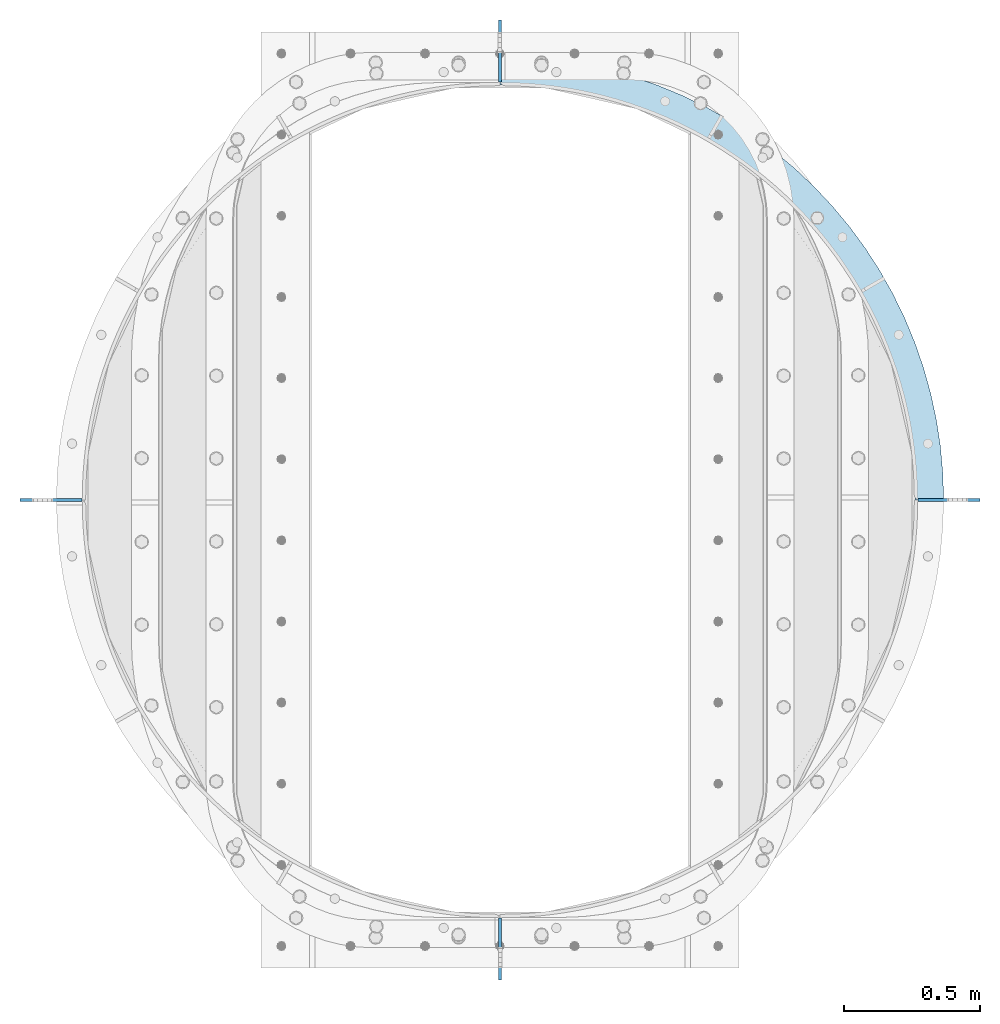
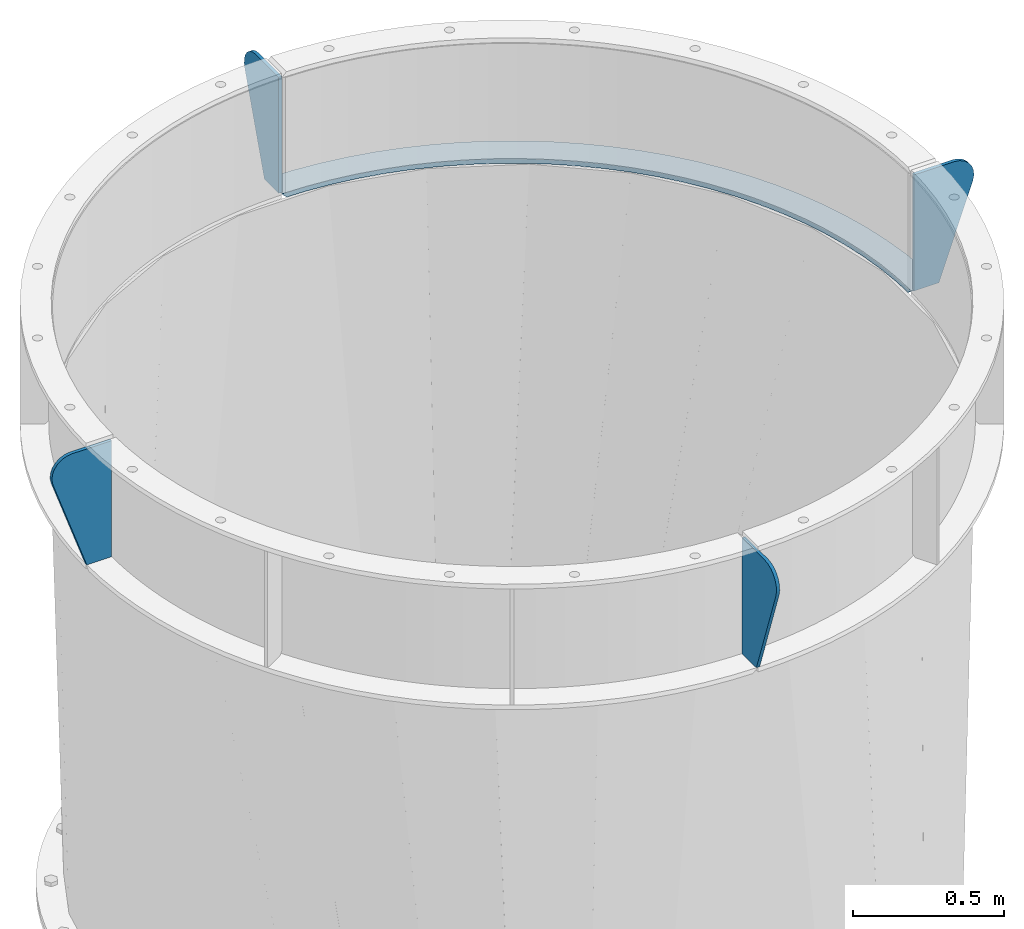
# One storey, part 15 of 15: 5 plates, 1 element without a shape of its own.
"""IFC2X3 building model written with IfcOpenShell, lengths in millimetres."""

import ifcopenshell
import ifcopenshell.guid

model = None  # the IFC model being written
_history = None  # IfcOwnerHistory: only IFC2X3 demands one
_inside = {}  # id of a spatial element -> (the spatial element, [elements in it])
_under = {}  # id of a project, library or spatial element -> (it, [spatial elements below it])
_declared = {}  # id of a project -> (the project, [libraries it declares])
_typed = {}  # id of a type object -> (the type object, [elements of that type])
_made_of = {}  # id of a material, layer set ... -> (it, [elements and type objects made of it])


def new_model(schema):
    """Start an empty IFC model of exactly this schema.

    Asked for "IFC4X3", IfcOpenShell would pick the latest addendum, in which some entities
    have other attributes; the version numbers below select the first issue.
    IFC2X3 requires an IfcOwnerHistory on every rooted entity: one is made here for all.
    """
    global model, _history
    if schema == "IFC4X3":
        model = ifcopenshell.file(schema_version=(4, 3, 0, 0))
    else:
        model = ifcopenshell.file(schema=schema)
    _inside.clear()
    _under.clear()
    _declared.clear()
    _typed.clear()
    _made_of.clear()
    _history = None
    if model.schema == "IFC2X3":
        org = make("IfcOrganization", Name="unknown")
        user = make(
            "IfcPersonAndOrganization",
            ThePerson=make("IfcPerson", FamilyName="unknown"),
            TheOrganization=org,
        )
        app = make(
            "IfcApplication",
            ApplicationDeveloper=org,
            Version="unknown",
            ApplicationFullName="unknown",
            ApplicationIdentifier="unknown",
        )
        _history = make(
            "IfcOwnerHistory",
            OwningUser=user,
            OwningApplication=app,
            ChangeAction="ADDED",
            CreationDate=0,
        )
    return model


def make(cls, **values):
    """One entity of the class cls with the attributes given. An attribute that is None is left unset."""
    return model.create_entity(
        cls, **{name: value for name, value in values.items() if value is not None}
    )


def rooted(cls, **values):
    """An entity with a GlobalId (a new one), such as an element, a storey or a relation."""
    return make(cls, GlobalId=ifcopenshell.guid.new(), OwnerHistory=_history, **values)


def si_unit(unit_type, name, prefix=None):
    """IfcSIUnit, for example si_unit("LENGTHUNIT", "METRE", prefix="MILLI")."""
    return make("IfcSIUnit", UnitType=unit_type, Prefix=prefix, Name=name)


def assignment(units):
    """IfcUnitAssignment: the units of a project."""
    return None if units is None else make("IfcUnitAssignment", Units=units)


def point(xyz):
    """IfcCartesianPoint."""
    return None if xyz is None else make("IfcCartesianPoint", Coordinates=xyz)


def direction(xyz):
    """IfcDirection."""
    return None if xyz is None else make("IfcDirection", DirectionRatios=xyz)


def frame(location, z_axis=None, x_axis=None):
    """IfcAxis2Placement3D, a coordinate frame: its origin and axes. An axis left out is left unset."""
    return make(
        "IfcAxis2Placement3D",
        Location=point(location),
        Axis=direction(z_axis),
        RefDirection=direction(x_axis),
    )


def origin_with_axes():
    """The frame at (0, 0, 0) with the z axis (0, 0, 1) and the x axis (1, 0, 0) written out."""
    return frame((0.0, 0.0, 0.0), z_axis=(0.0, 0.0, 1.0), x_axis=(1.0, 0.0, 0.0))


def place(relative_to, where):
    """IfcLocalPlacement: puts the frame where relative to a parent placement (None: the world)."""
    return make(
        "IfcLocalPlacement", PlacementRelTo=relative_to, RelativePlacement=where
    )


def context(
    kind, dimensions, precision=None, world=None, true_north=None, identifier=None
):
    """IfcGeometricRepresentationContext, for example the 3D "Model" context."""
    return make(
        "IfcGeometricRepresentationContext",
        ContextIdentifier=identifier,
        ContextType=kind,
        CoordinateSpaceDimension=dimensions,
        Precision=precision,
        WorldCoordinateSystem=world,
        TrueNorth=true_north,
    )


def subcontext(parent, identifier, kind, view, scale=None):
    """IfcGeometricRepresentationSubContext, for example "Body" below "Model"."""
    return make(
        "IfcGeometricRepresentationSubContext",
        ContextIdentifier=identifier,
        ContextType=kind,
        ParentContext=parent,
        TargetScale=scale,
        TargetView=view,
    )


def project(units=None, contexts=None):
    """IfcProject with its units and contexts."""
    return rooted(
        "IfcProject",
        Name="project",
        RepresentationContexts=contexts,
        UnitsInContext=assignment(units),
    )


def spatial(cls, under=None, at=None, **own):
    """A site, building, storey or space (cls), placed at a placement, below another one or the project."""
    s = rooted(cls, ObjectPlacement=at, **own)
    if under is not None:
        _under.setdefault(under.id(), (under, []))[1].append(s)
    return s


def faces_of(points, faces, orient=None, outer=None):
    """IfcFace entities. A face is a list of loops; a loop is a list of indices into points, from 0.

    orient and outer hold one flag for each loop. By default every Orientation is true, the
    first loop of a face is its IfcFaceOuterBound and the others are IfcFaceBound.
    """
    made = []
    for i, loops in enumerate(faces):
        bounds = []
        for j, loop in enumerate(loops):
            is_outer = j == 0 if outer is None else outer[i][j]
            bounds.append(
                make(
                    "IfcFaceOuterBound" if is_outer else "IfcFaceBound",
                    Bound=make("IfcPolyLoop", Polygon=[points[k] for k in loop]),
                    Orientation=True if orient is None else orient[i][j],
                )
            )
        made.append(make("IfcFace", Bounds=bounds))
    return made


def faceted_brep(points, faces, orient=None, outer=None, voids=None):
    """IfcFacetedBrep: a solid bounded by flat faces; with voids (closed shells), ...WithVoids."""
    shared = [point(p) for p in points]
    hull = make("IfcClosedShell", CfsFaces=faces_of(shared, faces, orient, outer))
    if voids is None:
        return make("IfcFacetedBrep", Outer=hull)
    return make(
        "IfcFacetedBrepWithVoids",
        Outer=hull,
        Voids=[
            make(cls, CfsFaces=faces_of(shared, fs, o, b)) for cls, fs, o, b in voids
        ],
    )


def shape(context_of_items, identifier, shape_type, items):
    """IfcShapeRepresentation: the items that make up one representation, for example the "Body"."""
    return make(
        "IfcShapeRepresentation",
        ContextOfItems=context_of_items,
        RepresentationIdentifier=identifier,
        RepresentationType=shape_type,
        Items=items,
    )


def material(Name=None, Category=None):
    """IfcMaterial."""
    return make("IfcMaterial", Name=Name, Category=Category)


def made_of(thing, what):
    """Note that an element or type object is made of a material, layer set ...; save() writes the relation."""
    if what is not None:
        _made_of.setdefault(what.id(), (what, []))[1].append(thing)
    return thing


def type_object(cls, material=None, **own):
    """A type object (cls), such as IfcWallType, which elements share."""
    return made_of(rooted(cls, **own), material)


def element(
    cls,
    number,
    at=None,
    inside=None,
    cuts=None,
    type_object=None,
    material=None,
    context=None,
    identifier="Body",
    shape_type=None,
    held_by="IfcProductDefinitionShape",
    body=None,
    shapes=None,
    **own,
):
    """One element of the class cls, such as IfcWall. Its Tag is "e" and its number.

    at: its placement. inside: the storey or other place that contains it. cuts: it is an
    opening in that element (IfcRelVoidsElement). A single representation is given by context,
    identifier, shape_type and body (its items); several are given by shapes. held_by: the class
    of the entity that holds the representations. save() writes the other relations.
    """
    e = rooted(cls, Tag="e%d" % number, ObjectPlacement=at, **own)
    if body is not None:
        shapes = [shape(context, identifier, shape_type, body)]
    if shapes is not None:
        e.Representation = make(held_by, Representations=shapes)
    if inside is not None:
        _inside.setdefault(inside.id(), (inside, []))[1].append(e)
    if cuts is not None:
        rooted(
            "IfcRelVoidsElement", RelatingBuildingElement=cuts, RelatedOpeningElement=e
        )
    if type_object is not None:
        _typed.setdefault(type_object.id(), (type_object, []))[1].append(e)
    return made_of(e, material)


def aggregate(whole, parts):
    """IfcRelAggregates: a whole, such as a stair, and the parts it consists of."""
    return rooted("IfcRelAggregates", RelatingObject=whole, RelatedObjects=parts)


def save(model, path):
    """Write the relations noted so far, then the file.

    IfcRelAggregates (storeys below a building ...), IfcRelContainedInSpatialStructure (elements
    in a storey), IfcRelDefinesByType, IfcRelAssociatesMaterial and IfcRelDeclares: one each for
    every whole, place, type object, material and project.
    """
    for whole, parts in _under.values():
        aggregate(whole, parts)
    for where, things in _inside.values():
        rooted(
            "IfcRelContainedInSpatialStructure",
            RelatedElements=things,
            RelatingStructure=where,
        )
    for kind, things in _typed.values():
        rooted("IfcRelDefinesByType", RelatedObjects=things, RelatingType=kind)
    for what, things in _made_of.values():
        rooted("IfcRelAssociatesMaterial", RelatedObjects=things, RelatingMaterial=what)
    for by, libraries in _declared.values():
        rooted("IfcRelDeclares", RelatingContext=by, RelatedDefinitions=libraries)
    model.write(path)


model = new_model("IFC2X3")

# Units and contexts
model_context = context("Model", 3, precision=1e-05, world=origin_with_axes())
body_context = subcontext(model_context, "Body", "Model", "MODEL_VIEW")
ifc_project = project(units=[si_unit("LENGTHUNIT", "METRE", prefix="MILLI"), si_unit("AREAUNIT", "SQUARE_METRE"), si_unit("VOLUMEUNIT", "CUBIC_METRE"), si_unit("MASSUNIT", "GRAM", prefix="KILO"), si_unit("TIMEUNIT", "SECOND"), si_unit("PLANEANGLEUNIT", "RADIAN"), si_unit("SOLIDANGLEUNIT", "STERADIAN"), si_unit("THERMODYNAMICTEMPERATUREUNIT", "DEGREE_CELSIUS"), si_unit("LUMINOUSINTENSITYUNIT", "LUMEN")], contexts=[model_context])

# Site, building, storey
site_placement = place(None, origin_with_axes())
site = spatial("IfcSite", under=ifc_project, at=site_placement, CompositionType="ELEMENT")
building_placement = place(site_placement, origin_with_axes())
building = spatial("IfcBuilding", under=site, at=building_placement, Name="Undefined", CompositionType="ELEMENT")
storey_placement = place(building_placement, origin_with_axes())
storey = spatial("IfcBuildingStorey", under=building, at=storey_placement, Name="Undefined", CompositionType="ELEMENT", Elevation=0.0)

# Assembly, plates
assembly_placement = place(storey_placement, origin_with_axes())
assembly = element("IfcElementAssembly", 1, at=assembly_placement, inside=storey, Name="TRANSITION", AssemblyPlace="NOTDEFINED", PredefinedType="RIGID_FRAME")
ifc_material = material(Name="STEEL/A36")
plate_type_1 = type_object("IfcPlateType", PredefinedType="NOTDEFINED")
plate_1_placement = place(assembly_placement, frame((-657.225000000269, 1720.85000000022, 6283.33), z_axis=(-1.0, 0.0, 0.0), x_axis=(0.0, 0.0, 1.0)))
plate_1 = element("IfcPlate", 2, at=plate_1_placement, type_object=plate_type_1, material=ifc_material, Name="PLATE", context=body_context, shape_type="Brep", body=[
    faceted_brep([(0.0, -6.34999999999991, 0.0), (1.81898940354586e-12, -6.34999999999991, 95.25), (1.81898940354586e-12, 6.34999999999991, 95.25), (0.0, 6.34999999999991, 0.0), (368.44076401667, -6.34999999999991, 224.702166797296), (368.44076401667, 6.34999999999991, 224.702166797296), (388.734484587208, -6.34999999999991, 228.848545423262), (388.734484587208, 6.34999999999991, 228.848545423262), (409.395098086102, -6.34999999999991, 227.376607872126), (409.395098086102, 6.34999999999991, 227.376607872126), (428.896028313952, -6.34999999999991, 220.395113006865), (428.896028313952, 6.34999999999991, 220.395113006865), (445.796386017711, -6.34999999999991, 208.419911138413), (445.796386017711, 6.34999999999991, 208.419911138413), (458.847433649809, -6.34999999999991, 192.335828758313), (458.847433649809, 6.34999999999991, 192.335828758313), (467.084852377538, -6.34999999999991, 173.331290273803), (467.084852377538, 6.34999999999991, 173.331290273803), (469.899993896484, -6.34999999999991, 152.81050742974), (469.899993896484, 6.34999999999991, 152.81050742974), (469.899993896484, -6.34999999999991, 1.81898940354586e-12), (469.899993896484, 6.34999999999991, 1.81898940354586e-12)], [[[0, 1, 2, 3]], [[1, 4, 5, 2]], [[4, 6, 7, 5]], [[6, 8, 9, 7]], [[8, 10, 11, 9]], [[10, 12, 13, 11]], [[12, 14, 15, 13]], [[14, 16, 17, 15]], [[16, 18, 19, 17]], [[18, 20, 21, 19]], [[20, 0, 3, 21]], [[5, 7, 9, 11, 13, 15, 17, 19, 21, 3, 2]], [[20, 18, 16, 14, 12, 10, 8, 6, 4, 1, 0]]]),
])
plate_2_placement = place(assembly_placement, frame((879.47499999978, 184.149999999731, 6283.33), z_axis=(0.0, -1.0, 0.0), x_axis=(0.0, 0.0, 1.0)))
plate_2 = element("IfcPlate", 3, at=plate_2_placement, type_object=plate_type_1, material=ifc_material, Name="PLATE", context=body_context, shape_type="Brep", body=[
    faceted_brep([(0.0, -6.34999999999991, 0.0), (1.81898940354586e-12, -6.34999999999991, 95.25), (1.81898940354586e-12, 6.34999999999991, 95.25), (0.0, 6.34999999999991, 0.0), (368.44076401667, -6.34999999999991, 224.702166797296), (368.44076401667, 6.34999999999991, 224.702166797296), (388.734484587208, -6.34999999999991, 228.848545423262), (388.734484587208, 6.34999999999991, 228.848545423262), (409.395098086102, -6.34999999999991, 227.376607872126), (409.395098086102, 6.34999999999991, 227.376607872126), (428.896028313952, -6.34999999999991, 220.395113006865), (428.896028313952, 6.34999999999991, 220.395113006865), (445.796386017711, -6.34999999999991, 208.419911138413), (445.796386017711, 6.34999999999991, 208.419911138413), (458.847433649809, -6.34999999999991, 192.335828758313), (458.847433649809, 6.34999999999991, 192.335828758313), (467.084852377538, -6.34999999999991, 173.331290273803), (467.084852377538, 6.34999999999991, 173.331290273803), (469.899993896484, -6.34999999999991, 152.81050742974), (469.899993896484, 6.34999999999991, 152.81050742974), (469.899993896484, -6.34999999999991, 1.81898940354586e-12), (469.899993896484, 6.34999999999991, 1.81898940354586e-12)], [[[0, 1, 2, 3]], [[1, 4, 5, 2]], [[4, 6, 7, 5]], [[6, 8, 9, 7]], [[8, 10, 11, 9]], [[10, 12, 13, 11]], [[12, 14, 15, 13]], [[14, 16, 17, 15]], [[16, 18, 19, 17]], [[18, 20, 21, 19]], [[20, 0, 3, 21]], [[5, 7, 9, 11, 13, 15, 17, 19, 21, 3, 2]], [[20, 18, 16, 14, 12, 10, 8, 6, 4, 1, 0]]]),
])
plate_3_placement = place(assembly_placement, frame((2416.17500000027, 1720.84999999978, 6283.33), z_axis=(1.0, 0.0, 0.0), x_axis=(0.0, 0.0, 1.0)))
plate_3 = element("IfcPlate", 4, at=plate_3_placement, type_object=plate_type_1, material=ifc_material, Name="PLATE", context=body_context, shape_type="Brep", body=[
    faceted_brep([(0.0, -6.34999999999991, 0.0), (1.81898940354586e-12, -6.34999999999991, 95.25), (1.81898940354586e-12, 6.34999999999991, 95.25), (0.0, 6.34999999999991, 0.0), (368.44076401667, -6.34999999999991, 224.702166797296), (368.44076401667, 6.34999999999991, 224.702166797296), (388.734484587208, -6.34999999999991, 228.848545423262), (388.734484587208, 6.34999999999991, 228.848545423262), (409.395098086102, -6.34999999999991, 227.376607872126), (409.395098086102, 6.34999999999991, 227.376607872126), (428.896028313952, -6.34999999999991, 220.395113006865), (428.896028313952, 6.34999999999991, 220.395113006865), (445.796386017711, -6.34999999999991, 208.419911138413), (445.796386017711, 6.34999999999991, 208.419911138413), (458.847433649809, -6.34999999999991, 192.335828758313), (458.847433649809, 6.34999999999991, 192.335828758313), (467.084852377538, -6.34999999999991, 173.331290273803), (467.084852377538, 6.34999999999991, 173.331290273803), (469.899993896484, -6.34999999999991, 152.81050742974), (469.899993896484, 6.34999999999991, 152.81050742974), (469.899993896484, -6.34999999999991, 1.81898940354586e-12), (469.899993896484, 6.34999999999991, 1.81898940354586e-12)], [[[0, 1, 2, 3]], [[1, 4, 5, 2]], [[4, 6, 7, 5]], [[6, 8, 9, 7]], [[8, 10, 11, 9]], [[10, 12, 13, 11]], [[12, 14, 15, 13]], [[14, 16, 17, 15]], [[16, 18, 19, 17]], [[18, 20, 21, 19]], [[20, 0, 3, 21]], [[5, 7, 9, 11, 13, 15, 17, 19, 21, 3, 2]], [[20, 18, 16, 14, 12, 10, 8, 6, 4, 1, 0]]]),
])
plate_4_placement = place(assembly_placement, frame((879.47500000022, 3257.55000000027, 6283.325), z_axis=(0.0, 1.0, 0.0), x_axis=(0.0, 0.0, 1.0)))
plate_4 = element("IfcPlate", 5, at=plate_4_placement, type_object=plate_type_1, material=ifc_material, Name="PLATE", context=body_context, shape_type="Brep", body=[
    faceted_brep([(0.0, -6.34999999999991, 0.0), (1.81898940354586e-12, -6.34999999999991, 95.25), (1.81898940354586e-12, 6.34999999999991, 95.25), (0.0, 6.34999999999991, 0.0), (368.44076401667, -6.34999999999991, 224.702166797296), (368.44076401667, 6.34999999999991, 224.702166797296), (388.734484587208, -6.34999999999991, 228.848545423262), (388.734484587208, 6.34999999999991, 228.848545423262), (409.395098086102, -6.34999999999991, 227.376607872126), (409.395098086102, 6.34999999999991, 227.376607872126), (428.896028313952, -6.34999999999991, 220.395113006865), (428.896028313952, 6.34999999999991, 220.395113006865), (445.796386017711, -6.34999999999991, 208.419911138413), (445.796386017711, 6.34999999999991, 208.419911138413), (458.847433649809, -6.34999999999991, 192.335828758313), (458.847433649809, 6.34999999999991, 192.335828758313), (467.084852377538, -6.34999999999991, 173.331290273803), (467.084852377538, 6.34999999999991, 173.331290273803), (469.899993896484, -6.34999999999991, 152.81050742974), (469.899993896484, 6.34999999999991, 152.81050742974), (469.899993896484, -6.34999999999991, 1.81898940354586e-12), (469.899993896484, 6.34999999999991, 1.81898940354586e-12)], [[[0, 1, 2, 3]], [[1, 4, 5, 2]], [[4, 6, 7, 5]], [[6, 8, 9, 7]], [[8, 10, 11, 9]], [[10, 12, 13, 11]], [[12, 14, 15, 13]], [[14, 16, 17, 15]], [[16, 18, 19, 17]], [[18, 20, 21, 19]], [[20, 0, 3, 21]], [[5, 7, 9, 11, 13, 15, 17, 19, 21, 3, 2]], [[20, 18, 16, 14, 12, 10, 8, 6, 4, 1, 0]]]),
])
plate_type_2 = type_object("IfcPlateType", PredefinedType="NOTDEFINED")
plate_5_placement = place(assembly_placement, frame((879.475000000271, 3352.79999999978, 6273.805), z_axis=(1.0, 0.0, 0.0), x_axis=(0.0, -1.0, 0.0)))
plate_5 = element("IfcPlate", 6, at=plate_5_placement, type_object=plate_type_2, material=ifc_material, Name="PLATE", context=body_context, shape_type="Brep", body=[
    faceted_brep([(103.76313049706, 9.52499999999964, 19.05), (103.1875, -9.52499999999964, 0.0), (0.0, -9.52499999999964, 0.0), (0.57563035489018, 9.52499999999964, 19.05), (1612.89995117188, 9.52499999999964, 1631.37432081696), (1631.94995117188, -9.52499999999964, 1631.94995117188), (1631.94995117188, -9.52499999999964, 1528.76245117188), (1612.89995117188, 9.52499999999964, 1528.18682067481), (2.97740452312382, -9.52499999999964, 98.5346858164392), (2.97740452312382, 9.52499999999964, 98.5346858164392), (11.8987531805783, -9.52499999999964, 196.709829232645), (11.8987531805783, 9.52499999999964, 196.709829232645), (26.7314929387344, -9.52499999999964, 294.167199800127), (26.7314929387344, 9.52499999999964, 294.167199800127), (47.4215007392556, -9.52499999999964, 390.55118614576), (47.4215007392556, 9.52499999999964, 390.55118614576), (73.8932809881087, -9.52499999999964, 485.510093559006), (73.8932809881087, 9.52499999999964, 485.510093559006), (106.050241030797, -9.52499999999964, 578.697427287759), (106.050241030797, 9.52499999999964, 578.697427287759), (143.77504360848, -9.52499999999964, 669.77315686011), (143.77504360848, 9.52499999999964, 669.77315686011), (186.930035008899, -9.52499999999964, 758.404956818652), (186.930035008899, 9.52499999999964, 758.404956818652), (235.357747349844, -9.52499999999964, 844.269419340023), (235.357747349844, 9.52499999999964, 844.269419340023), (288.881473162371, -9.52499999999964, 927.053234314973), (288.881473162371, 9.52499999999964, 927.053234314973), (347.30591017719, -9.52499999999964, 1006.45433258296), (347.30591017719, 9.52499999999964, 1006.45433258296), (410.417873961457, -9.52499999999964, 1082.18298814976), (410.417873961457, 9.52499999999964, 1082.18298814976), (477.987075805645, -9.52499999999964, 1153.96287536617), (477.987075805645, 9.52499999999964, 1153.96287536617), (549.766963022063, -9.52499999999964, 1221.53207721036), (549.766963022063, 9.52499999999964, 1221.53207721036), (625.495618588867, -9.52499999999964, 1284.64404099462), (625.495618588867, 9.52499999999964, 1284.64404099462), (704.896716856861, -9.52499999999964, 1343.06847800943), (704.896716856861, 9.52499999999964, 1343.06847800943), (787.680531831816, -9.52499999999964, 1396.59220382195), (787.680531831816, 9.52499999999964, 1396.59220382195), (873.544994353191, -9.52499999999964, 1445.01991616288), (873.544994353191, 9.52499999999964, 1445.01991616288), (962.176794311736, -9.52499999999964, 1488.1749075633), (962.176794311736, 9.52499999999964, 1488.1749075633), (1053.25252388409, -9.52499999999964, 1525.89971014097), (1053.25252388409, 9.52499999999964, 1525.89971014097), (1146.43985761284, -9.52499999999964, 1558.05667018365), (1146.43985761284, 9.52499999999964, 1558.05667018365), (1241.39876502609, -9.52499999999964, 1584.52845043249), (1241.39876502609, 9.52499999999964, 1584.52845043249), (1337.78275137173, -9.52499999999964, 1605.21845823301), (1337.78275137173, 9.52499999999964, 1605.21845823301), (1435.24012193921, -9.52499999999964, 1620.05119799115), (1435.24012193921, 9.52499999999964, 1620.05119799115), (1533.41526535541, -9.52499999999964, 1628.9725466486), (1533.41526535541, 9.52499999999964, 1628.9725466486), (1539.64557176765, -9.52499999999964, 1525.97330598564), (1539.64557176765, 9.52499999999964, 1525.97330598564), (1447.67800108681, -9.52499999999964, 1517.61604978902), (1447.67800108681, 9.52499999999964, 1517.61604978902), (1356.3828188116, -9.52499999999964, 1503.7211773028), (1356.3828188116, 9.52499999999964, 1503.7211773028), (1266.09315115196, -9.52499999999964, 1484.33938940837), (1266.09315115196, 9.52499999999964, 1484.33938940837), (1177.13845530415, -9.52499999999964, 1459.54140814586), (1177.13845530415, 9.52499999999964, 1459.54140814586), (1089.84331729719, -9.52499999999964, 1429.41771865703), (1089.84331729719, 9.52499999999964, 1429.41771865703), (1004.5262676137, -9.52499999999964, 1394.07823901488), (1004.5262676137, 9.52499999999964, 1394.07823901488), (921.498618906718, -9.52499999999964, 1353.65191914449), (921.498618906718, 9.52499999999964, 1353.65191914449), (841.063330053642, -9.52499999999964, 1308.28627029875), (841.063330053642, 9.52499999999964, 1308.28627029875), (763.513900692163, -9.52499999999964, 1258.1468268058), (763.513900692163, 9.52499999999964, 1258.1468268058), (689.133300271954, -9.52499999999964, 1203.41654205227), (689.133300271954, 9.52499999999964, 1203.41654205227), (618.192935529858, -9.52499999999964, 1144.29512090619), (618.192935529858, 9.52499999999964, 1144.29512090619), (550.95166015617, -9.52499999999964, 1080.99829101564), (550.95166015617, 9.52499999999964, 1080.99829101564), (487.654830265622, -9.52499999999964, 1013.75701564195), (487.654830265622, 9.52499999999964, 1013.75701564195), (428.533409119548, -9.52499999999964, 942.816650899848), (428.533409119548, 9.52499999999964, 942.816650899848), (373.80312436602, -9.52499999999964, 868.436050479634), (373.80312436602, 9.52499999999964, 868.436050479634), (323.663680873077, -9.52499999999964, 790.88662111815), (323.663680873077, 9.52499999999964, 790.88662111815), (278.298032027336, -9.52499999999964, 710.451332265068), (278.298032027336, 9.52499999999964, 710.451332265068), (237.871712156949, -9.52499999999964, 627.423683558081), (237.871712156949, 9.52499999999964, 627.423683558081), (202.532232514805, -9.52499999999964, 542.106633874585), (202.532232514805, 9.52499999999964, 542.106633874585), (172.408543025982, -9.52499999999964, 454.811495867622), (172.408543025982, 9.52499999999964, 454.811495867622), (147.610561763468, -9.52499999999964, 365.856800019807), (147.610561763468, 9.52499999999964, 365.856800019807), (128.228773869042, -9.52499999999964, 275.567132360162), (128.228773869042, 9.52499999999964, 275.567132360162), (114.333901382821, -9.52499999999964, 184.271950084946), (114.333901382821, 9.52499999999964, 184.271950084946), (105.976645186203, -9.52499999999964, 92.3043794040959), (105.976645186203, 9.52499999999964, 92.3043794040959)], [[[0, 1, 2, 3]], [[4, 5, 6, 7]], [[8, 9, 3, 2]], [[8, 10, 11, 9]], [[10, 12, 13, 11]], [[12, 14, 15, 13]], [[14, 16, 17, 15]], [[16, 18, 19, 17]], [[18, 20, 21, 19]], [[20, 22, 23, 21]], [[22, 24, 25, 23]], [[24, 26, 27, 25]], [[26, 28, 29, 27]], [[28, 30, 31, 29]], [[30, 32, 33, 31]], [[32, 34, 35, 33]], [[34, 36, 37, 35]], [[36, 38, 39, 37]], [[38, 40, 41, 39]], [[40, 42, 43, 41]], [[42, 44, 45, 43]], [[44, 46, 47, 45]], [[46, 48, 49, 47]], [[48, 50, 51, 49]], [[50, 52, 53, 51]], [[52, 54, 55, 53]], [[54, 56, 57, 55]], [[57, 56, 5, 4]], [[58, 59, 7, 6]], [[58, 60, 61, 59]], [[60, 62, 63, 61]], [[62, 64, 65, 63]], [[64, 66, 67, 65]], [[66, 68, 69, 67]], [[68, 70, 71, 69]], [[70, 72, 73, 71]], [[72, 74, 75, 73]], [[74, 76, 77, 75]], [[76, 78, 79, 77]], [[78, 80, 81, 79]], [[80, 82, 83, 81]], [[82, 84, 85, 83]], [[84, 86, 87, 85]], [[86, 88, 89, 87]], [[88, 90, 91, 89]], [[90, 92, 93, 91]], [[92, 94, 95, 93]], [[94, 96, 97, 95]], [[96, 98, 99, 97]], [[98, 100, 101, 99]], [[100, 102, 103, 101]], [[102, 104, 105, 103]], [[104, 106, 107, 105]], [[107, 106, 1, 0]], [[59, 61, 63, 65, 67, 69, 71, 73, 75, 77, 79, 81, 83, 85, 87, 89, 91, 93, 95, 97, 99, 101, 103, 105, 107, 0, 3, 9, 11, 13, 15, 17, 19, 21, 23, 25, 27, 29, 31, 33, 35, 37, 39, 41, 43, 45, 47, 49, 51, 53, 55, 57, 4, 7]], [[1, 106, 104, 102, 100, 98, 96, 94, 92, 90, 88, 86, 84, 82, 80, 78, 76, 74, 72, 70, 68, 66, 64, 62, 60, 58, 6, 5, 56, 54, 52, 50, 48, 46, 44, 42, 40, 38, 36, 34, 32, 30, 28, 26, 24, 22, 20, 18, 16, 14, 12, 10, 8, 2]]]),
])
aggregate(assembly, [plate_1, plate_2, plate_3, plate_4, plate_5])

save(model, "model.ifc")
